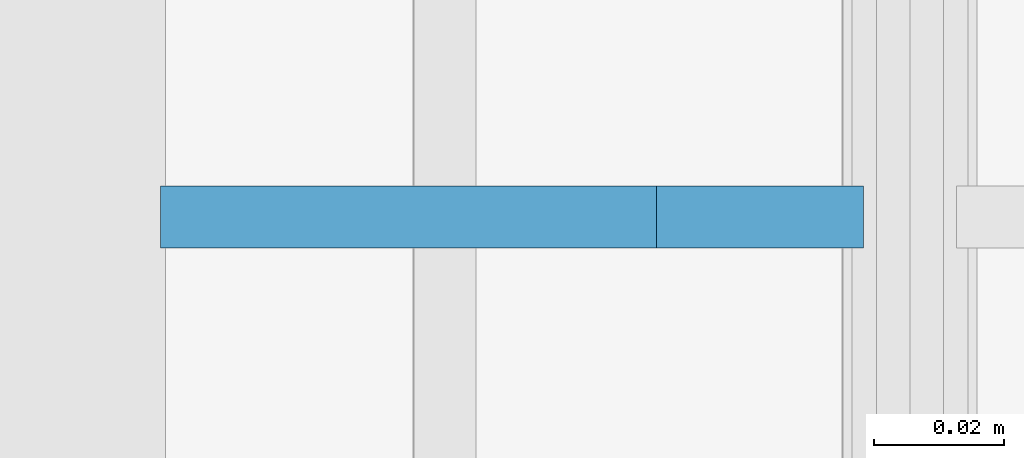
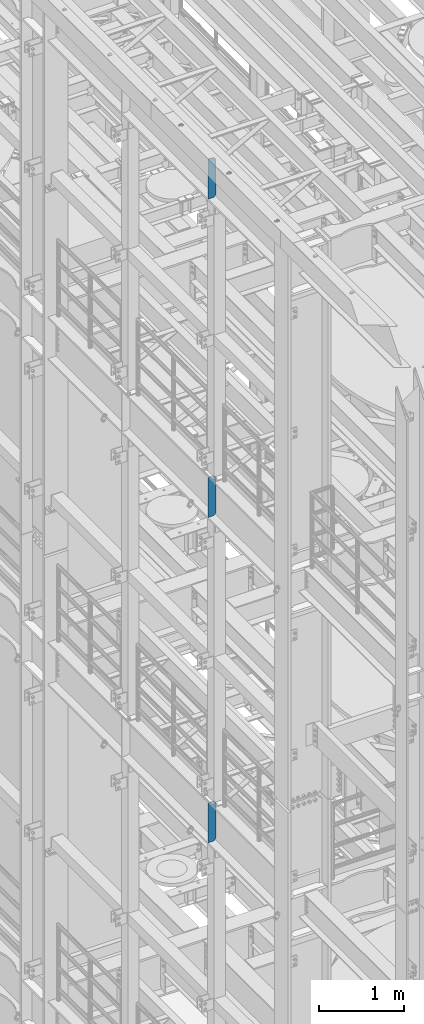
# One storey, part 1486 of 1876: 3 plates, 3 elements without a shape of their own.
"""IFC2X3 building model written with IfcOpenShell, lengths in millimetres."""

from ifc_helpers import new_model, si_unit, frame, origin_with_axes, place, context, subcontext, project, spatial, faceted_brep, material, type_object, element, aggregate, save


model = new_model("IFC2X3")

# Units and contexts
model_context = context("Model", 3, precision=1e-05, world=origin_with_axes())
body_context = subcontext(model_context, "Body", "Model", "MODEL_VIEW")
ifc_project = project(units=[si_unit("LENGTHUNIT", "METRE", prefix="MILLI"), si_unit("AREAUNIT", "SQUARE_METRE"), si_unit("VOLUMEUNIT", "CUBIC_METRE"), si_unit("MASSUNIT", "GRAM", prefix="KILO"), si_unit("TIMEUNIT", "SECOND"), si_unit("PLANEANGLEUNIT", "RADIAN"), si_unit("SOLIDANGLEUNIT", "STERADIAN"), si_unit("THERMODYNAMICTEMPERATUREUNIT", "DEGREE_CELSIUS"), si_unit("LUMINOUSINTENSITYUNIT", "LUMEN")], contexts=[model_context])

# Site, building, storey
site_placement = place(None, origin_with_axes())
site = spatial("IfcSite", under=ifc_project, at=site_placement, CompositionType="ELEMENT")
building_placement = place(site_placement, origin_with_axes())
building = spatial("IfcBuilding", under=site, at=building_placement, Name="Undefined", CompositionType="ELEMENT")
storey_placement = place(building_placement, origin_with_axes())
storey = spatial("IfcBuildingStorey", under=building, at=storey_placement, Name="Undefined", CompositionType="ELEMENT", Elevation=0.0)

# Assembly, plate
assembly_1_placement = place(storey_placement, origin_with_axes())
assembly_1 = element("IfcElementAssembly", 1, at=assembly_1_placement, inside=storey, Name="BEAM", AssemblyPlace="NOTDEFINED", PredefinedType="RIGID_FRAME")
ifc_material = material(Name="STEEL/A36")
plate_type = type_object("IfcPlateType", PredefinedType="NOTDEFINED")
plate_1_placement = place(assembly_1_placement, frame((-7.14374915193636, -2540.0000000159, 21958.3), z_axis=(0.0, 0.0, 1.0), x_axis=(-1.0, 0.0, 0.0)))
plate_1 = element("IfcPlate", 2, at=plate_1_placement, type_object=plate_type, material=ifc_material, Name="PLATE", context=body_context, shape_type="Brep", body=[
    faceted_brep([(-9.76996261670138e-14, -4.76250000000073, 31.75), (0.0, -4.76249999999982, 539.75), (0.0, 4.76249999999982, 539.75), (-9.76996261670138e-14, 4.76250000000073, 31.75), (31.75, -4.76249999999982, 571.5), (31.75, 4.76249999999982, 571.5), (107.949996948242, -4.76249999999982, 571.5), (107.949996948242, 4.76249999999982, 571.5), (107.950006484985, -4.76250000000073, 0.0), (107.950006484985, 4.76250000000073, 0.0), (31.75, -4.76250000000073, 0.0), (31.75, 4.76250000000073, 0.0)], [[[0, 1, 2, 3]], [[1, 4, 5, 2]], [[4, 6, 7, 5]], [[6, 8, 9, 7]], [[8, 10, 11, 9]], [[10, 0, 3, 11]], [[5, 7, 9, 11, 3, 2]], [[10, 8, 6, 4, 1, 0]]]),
])
aggregate(assembly_1, [plate_1])

assembly_2_placement = place(storey_placement, origin_with_axes())
assembly_2 = element("IfcElementAssembly", 3, at=assembly_2_placement, inside=storey, Name="BEAM", AssemblyPlace="NOTDEFINED", PredefinedType="RIGID_FRAME")
plate_2_placement = place(assembly_2_placement, frame((-7.14374915193636, -2540.0000000159, 17386.3), z_axis=(0.0, 0.0, 1.0), x_axis=(-1.0, 0.0, 0.0)))
plate_2 = element("IfcPlate", 4, at=plate_2_placement, type_object=plate_type, material=ifc_material, Name="PLATE", context=body_context, shape_type="Brep", body=[
    faceted_brep([(-9.76996261670138e-14, -4.76250000000073, 31.75), (0.0, -4.76249999999982, 539.75), (0.0, 4.76249999999982, 539.75), (-9.76996261670138e-14, 4.76250000000073, 31.75), (31.75, -4.76249999999982, 571.5), (31.75, 4.76249999999982, 571.5), (107.949996948242, -4.76249999999982, 571.5), (107.949996948242, 4.76249999999982, 571.5), (107.950006484985, -4.76250000000073, 0.0), (107.950006484985, 4.76250000000073, 0.0), (31.75, -4.76250000000073, 0.0), (31.75, 4.76250000000073, 0.0)], [[[0, 1, 2, 3]], [[1, 4, 5, 2]], [[4, 6, 7, 5]], [[6, 8, 9, 7]], [[8, 10, 11, 9]], [[10, 0, 3, 11]], [[5, 7, 9, 11, 3, 2]], [[10, 8, 6, 4, 1, 0]]]),
])
aggregate(assembly_2, [plate_2])

assembly_3_placement = place(storey_placement, origin_with_axes())
assembly_3 = element("IfcElementAssembly", 5, at=assembly_3_placement, inside=storey, Name="BEAM", AssemblyPlace="NOTDEFINED", PredefinedType="RIGID_FRAME")
plate_3_placement = place(assembly_3_placement, frame((-7.14374915193636, -2540.0000000159, 12712.7), z_axis=(0.0, 0.0, 1.0), x_axis=(-1.0, 0.0, 0.0)))
plate_3 = element("IfcPlate", 6, at=plate_3_placement, type_object=plate_type, material=ifc_material, Name="PLATE", context=body_context, shape_type="Brep", body=[
    faceted_brep([(-9.76996261670138e-14, -4.76250000000073, 31.75), (0.0, -4.76249999999982, 539.75), (0.0, 4.76249999999982, 539.75), (-9.76996261670138e-14, 4.76250000000073, 31.75), (31.75, -4.76249999999982, 571.5), (31.75, 4.76249999999982, 571.5), (107.949996948242, -4.76249999999982, 571.5), (107.949996948242, 4.76249999999982, 571.5), (107.950006484985, -4.76250000000073, 0.0), (107.950006484985, 4.76250000000073, 0.0), (31.75, -4.76250000000073, 0.0), (31.75, 4.76250000000073, 0.0)], [[[0, 1, 2, 3]], [[1, 4, 5, 2]], [[4, 6, 7, 5]], [[6, 8, 9, 7]], [[8, 10, 11, 9]], [[10, 0, 3, 11]], [[5, 7, 9, 11, 3, 2]], [[10, 8, 6, 4, 1, 0]]]),
])
aggregate(assembly_3, [plate_3])

save(model, "model.ifc")
